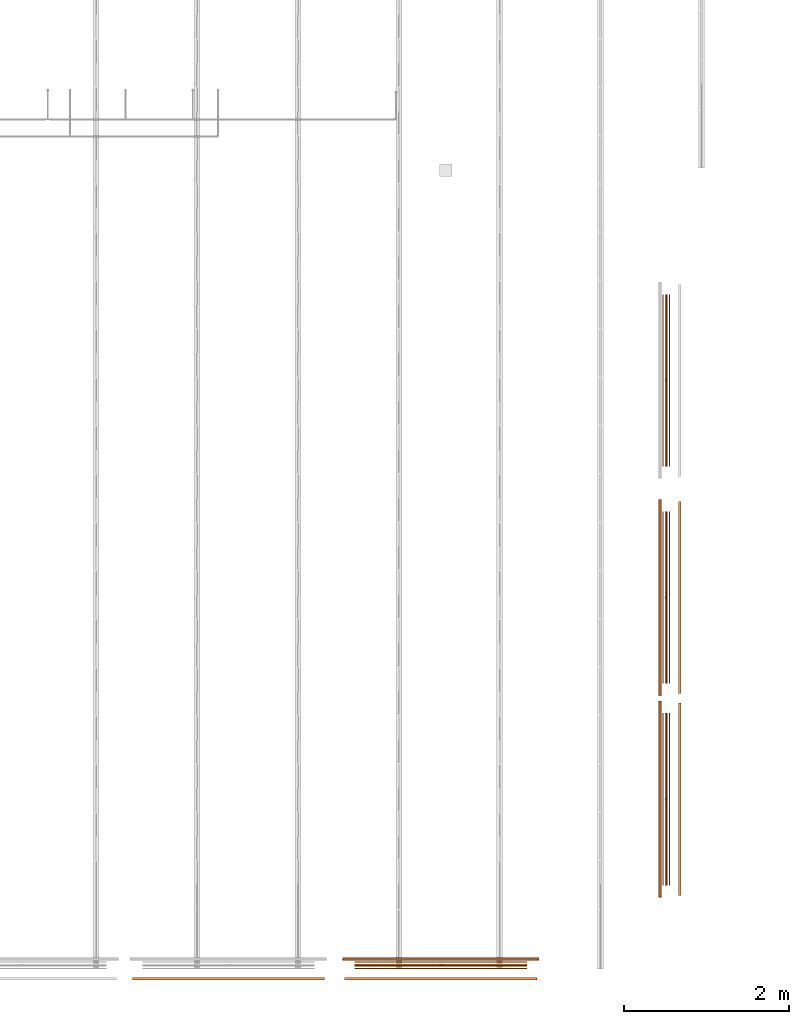
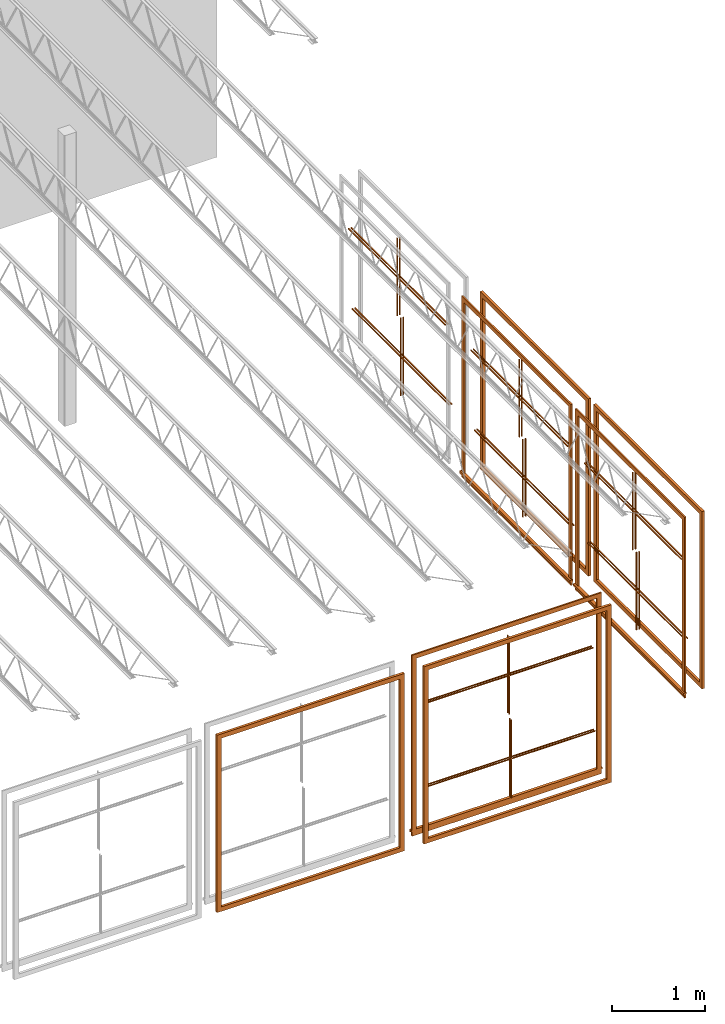
# One storey, part 28 of 31: 15 proxies.
"""IFC2X3 building model written with IfcOpenShell, lengths in feet."""

from ifc_helpers import new_model, entity, si_unit, converted_unit, derived_unit, direction, frame, frame_2d, origin, origin_2d_with_axis, place, context, subcontext, project, spatial, polyline, rectangle, outline, extrude, source, transform, mapped, material, material_list, type_object, type_shapes, element, save


model = new_model("IFC2X3")

# Units and contexts
model_context = context("Model", 3, precision=0.0001, world=origin(), true_north=direction((6.12303176911189e-17, 1.0)))
body_context = subcontext(model_context, "Body", "Model", "MODEL_VIEW")
ifc_project = project(units=[converted_unit("LENGTHUNIT", "FOOT", entity("IfcRatioMeasure", 0.3048), si_unit("LENGTHUNIT", "METRE"), dimensions=[1, 0, 0, 0, 0, 0, 0]), converted_unit("AREAUNIT", "SQUARE FOOT", entity("IfcRatioMeasure", 0.09290304), si_unit("AREAUNIT", "SQUARE_METRE"), dimensions=[2, 0, 0, 0, 0, 0, 0]), converted_unit("VOLUMEUNIT", "CUBIC FOOT", entity("IfcRatioMeasure", 0.028316846592), si_unit("VOLUMEUNIT", "CUBIC_METRE"), dimensions=[3, 0, 0, 0, 0, 0, 0]), converted_unit("PLANEANGLEUNIT", "DEGREE", entity("IfcRatioMeasure", 0.0174532925199433), si_unit("PLANEANGLEUNIT", "RADIAN"), dimensions=[0, 0, 0, 0, 0, 0, 0]), si_unit("MASSUNIT", "GRAM", prefix="KILO"), derived_unit("MASSDENSITYUNIT", [(si_unit("MASSUNIT", "GRAM", prefix="KILO"), 1), (si_unit("LENGTHUNIT", "METRE"), -3)]), si_unit("TIMEUNIT", "SECOND"), si_unit("FREQUENCYUNIT", "HERTZ"), si_unit("THERMODYNAMICTEMPERATUREUNIT", "DEGREE_CELSIUS"), derived_unit("THERMALTRANSMITTANCEUNIT", [(si_unit("MASSUNIT", "GRAM", prefix="KILO"), 1), (si_unit("THERMODYNAMICTEMPERATUREUNIT", "KELVIN"), -1), (si_unit("TIMEUNIT", "SECOND"), -3)]), derived_unit("VOLUMETRICFLOWRATEUNIT", [(si_unit("LENGTHUNIT", "METRE"), 3), (si_unit("TIMEUNIT", "SECOND"), -1)]), si_unit("ELECTRICCURRENTUNIT", "AMPERE"), si_unit("ELECTRICVOLTAGEUNIT", "VOLT"), si_unit("POWERUNIT", "WATT"), si_unit("FORCEUNIT", "NEWTON"), si_unit("ILLUMINANCEUNIT", "LUX"), si_unit("LUMINOUSFLUXUNIT", "LUMEN"), si_unit("LUMINOUSINTENSITYUNIT", "CANDELA"), derived_unit("USERDEFINED", [(si_unit("MASSUNIT", "GRAM", prefix="KILO"), -1), (si_unit("LENGTHUNIT", "METRE"), -2), (si_unit("TIMEUNIT", "SECOND"), 3), (si_unit("LUMINOUSFLUXUNIT", "LUMEN"), 1)]), derived_unit("LINEARVELOCITYUNIT", [(si_unit("LENGTHUNIT", "METRE"), 1), (si_unit("TIMEUNIT", "SECOND"), -1)]), si_unit("PRESSUREUNIT", "PASCAL"), derived_unit("USERDEFINED", [(si_unit("LENGTHUNIT", "METRE"), -2), (si_unit("MASSUNIT", "GRAM", prefix="KILO"), 1), (si_unit("TIMEUNIT", "SECOND"), -2)])], contexts=[model_context])

# Site, building, storey
site_placement = place(None, origin())
site = spatial("IfcSite", under=ifc_project, at=site_placement, CompositionType="ELEMENT")
building_placement = place(site_placement, origin())
building = spatial("IfcBuilding", under=site, at=building_placement, CompositionType="ELEMENT")
storey_placement = place(building_placement, frame((0.0, 0.0, 13.3333333333323)))
storey = spatial("IfcBuildingStorey", under=building, at=storey_placement, Name="Level 2", CompositionType="ELEMENT", Elevation=13.3333333333323)

# Proxies
ifc_material_1 = material(Name="Wood - Stained")
building_element_proxy_type_1 = type_object("IfcBuildingElementProxyType", Name="Trim-Window-Interior-Flat:Picture Frame", PredefinedType="NOTDEFINED", material=ifc_material_1)
shared_shape_1 = source(origin(), body_context, "Body", "SweptSolid", [
    extrude(outline(polyline([(-3.81249999999999, -3.81249999999998), (3.81249999999999, -3.81249999999998), (3.81249999999999, 3.81249999999998), (-3.81249999999999, 3.81249999999998), (-3.81249999999999, -3.81249999999998)]), holes=[polyline([(3.625, 3.62499999999997), (3.625, -3.62499999999998), (-3.62499999999999, -3.62499999999998), (-3.62499999999999, 3.62499999999997), (3.625, 3.62499999999997)])]), frame((32.9591979395684, -37.4400600419649, 20.0), z_axis=(0.0, 1.0, 0.0), x_axis=(1.0, 0.0, 0.0)), (0.0, 0.0, 1.0), 0.104166666666664),
])
type_shapes(building_element_proxy_type_1, [shared_shape_1])
proxy_1_placement = place(building_placement, origin())
element("IfcBuildingElementProxy", 1, at=proxy_1_placement, inside=storey, type_object=building_element_proxy_type_1, material=ifc_material_1, ObjectType="Picture Frame : Trim-Window-Interior-Flat:Picture Frame", context=body_context, shape_type="MappedRepresentation", body=[
    mapped(shared_shape_1, transform((0.0, 0.0, 0.0), scale=1.0)),
])
ifc_material_2 = material(Name="Clad - White 61141")
ifc_material_list_1 = material_list([ifc_material_1, ifc_material_2])
ifc_material_list_2 = material_list([ifc_material_1, ifc_material_2])
building_element_proxy_type_2 = type_object("IfcBuildingElementProxyType", Name="Muntin Pattern_2x2:Muntin Pattern_2x2", PredefinedType="NOTDEFINED", material=ifc_material_list_2)
shared_shape_2 = source(origin(), body_context, "Body", "SweptSolid", [
    extrude(outline(polyline([(-0.0208333333334068, -1.67187499999988), (0.0208333333332575, -1.67187499999988), (0.0208333333332575, -0.0208333333333712), (3.41666666666681, -0.0208333333333712), (3.41666666666681, 0.0208333333332931), (0.020833333333286, 0.0208333333332931), (0.020833333333286, 1.67187500000004), (-0.0208333333333854, 1.67187500000004), (-0.0208333333333854, 0.0208333333333037), (-3.41666666666651, 0.0208333333333037), (-3.41666666666651, -0.0208333333333641), (-0.0208333333334068, -0.0208333333333641), (-0.0208333333334068, -1.67187499999988)])), frame((41.3758646062349, -36.8567267086316, 21.7447916666666), z_axis=(0.0, 1.0, 0.0), x_axis=(1.0, 0.0, 0.0)), (0.0, 0.0, 1.0), 0.0416666666666572),
    extrude(outline(polyline([(-0.0208333333334139, -1.6718749999996), (0.0208333333332433, -1.6718749999996), (0.0208333333332433, -0.0208333333334636), (3.41666666666681, -0.0208333333334636), (3.41666666666681, 0.0208333333331936), (0.0208333333332718, 0.0208333333331936), (0.0208333333332718, 1.67187500000009), (-0.0208333333333783, 1.67187500000009), (-0.0208333333333783, 0.0208333333332149), (-3.4166666666665, 0.0208333333332149), (-3.4166666666665, -0.0208333333334494), (-0.0208333333334139, -0.0208333333334494), (-0.0208333333334139, -1.6718749999996)])), frame((41.3758646062349, -36.7525600419649, 21.7447916666663), z_axis=(0.0, 1.0, 0.0), x_axis=(1.0, 0.0, 0.0)), (0.0, 0.0, 1.0), 0.0416666666666501),
])
type_shapes(building_element_proxy_type_2, [shared_shape_2])
proxy_2_placement = place(building_placement, origin())
element("IfcBuildingElementProxy", 2, at=proxy_2_placement, inside=storey, type_object=building_element_proxy_type_2, material=ifc_material_list_1, ObjectType="Muntin Pattern_2x2 : Muntin Pattern_2x2:Muntin Pattern_2x2", context=body_context, shape_type="MappedRepresentation", body=[
    mapped(shared_shape_2, transform((0.0, 0.0, 0.0), scale=1.0)),
])
ifc_material_list_3 = material_list([ifc_material_1, ifc_material_2])
ifc_material_list_4 = material_list([ifc_material_1, ifc_material_2])
building_element_proxy_type_3 = type_object("IfcBuildingElementProxyType", Name="Muntin Pattern_2x2:Muntin Pattern_2x2", PredefinedType="NOTDEFINED", material=ifc_material_list_4)
shared_shape_3 = source(origin(), body_context, "Body", "SweptSolid", [
    extrude(outline(polyline([(-0.0208333333334068, -1.67187499999989), (0.0208333333332575, -1.67187499999989), (0.0208333333332575, -0.0208333333333748), (3.41666666666681, -0.0208333333333748), (3.41666666666681, 0.0208333333332895), (0.020833333333286, 0.0208333333332895), (0.020833333333286, 1.67187500000003), (-0.0208333333333854, 1.67187500000003), (-0.0208333333333854, 0.0208333333333002), (-3.41666666666651, 0.0208333333333002), (-3.41666666666651, -0.0208333333333677), (-0.0208333333334068, -0.0208333333333677), (-0.0208333333334068, -1.67187499999989)])), frame((41.3758646062349, -37.0025600419649, 18.2552083333333), z_axis=(0.0, 1.0, 0.0), x_axis=(1.0, 0.0, 0.0)), (0.0, 0.0, 1.0), 0.0416666666666572),
    extrude(outline(polyline([(-0.0208333333334139, -1.6718749999996), (0.0208333333332433, -1.6718749999996), (0.0208333333332433, -0.0208333333334672), (3.41666666666681, -0.0208333333334672), (3.41666666666681, 0.02083333333319), (0.0208333333332718, 0.02083333333319), (0.0208333333332718, 1.67187500000009), (-0.0208333333333783, 1.67187500000009), (-0.0208333333333783, 0.0208333333332149), (-3.4166666666665, 0.0208333333332149), (-3.4166666666665, -0.0208333333334458), (-0.0208333333334139, -0.0208333333334458), (-0.0208333333334139, -1.6718749999996)])), frame((41.3758646062349, -36.8983933752982, 18.2552083333331), z_axis=(0.0, 1.0, 0.0), x_axis=(1.0, 0.0, 0.0)), (0.0, 0.0, 1.0), 0.0416666666666501),
])
type_shapes(building_element_proxy_type_3, [shared_shape_3])
proxy_3_placement = place(building_placement, origin())
element("IfcBuildingElementProxy", 3, at=proxy_3_placement, inside=storey, type_object=building_element_proxy_type_3, material=ifc_material_list_3, ObjectType="Muntin Pattern_2x2 : Muntin Pattern_2x2:Muntin Pattern_2x2", context=body_context, shape_type="MappedRepresentation", body=[
    mapped(shared_shape_3, transform((0.0, 0.0, 0.0), scale=1.0)),
])
building_element_proxy_type_4 = type_object("IfcBuildingElementProxyType", Name="Trim-Window-Exterior-Flat:with Sill", PredefinedType="NOTDEFINED", material=ifc_material_2)
shared_shape_4 = source(origin(), body_context, "Body", "SweptSolid", [
    extrude(outline(polyline([(-3.85416666666666, -3.71354166666667), (-3.66666666666666, -3.71354166666667), (-3.66666666666666, 3.61979166666666), (3.66666666666666, 3.61979166666666), (3.66666666666666, -3.71354166666667), (3.85416666666666, -3.71354166666667), (3.85416666666666, 3.80729166666666), (-3.85416666666666, 3.80729166666666), (-3.85416666666666, -3.71354166666667)])), frame((41.3758646062351, -36.6692267086316, 20.046875), z_axis=(0.0, 1.0, 0.0), x_axis=(-1.0, 0.0, 0.0)), (0.0, 0.0, 1.0), 0.0625),
    extrude(outline(polyline([(0.0, -0.0524593146393144), (0.0624999999999574, -0.0524593146393144), (0.0624999999999574, 0.0436428358983321), (0.0, 0.0517073520273605), (-0.0624999999999218, 0.0517073520273605), (-0.0624999999999218, -0.0210694553372015), (0.0, -0.0210694553372015), (0.0, -0.0524593146393144)])), frame((37.4800312729017, -36.6067267086316, 16.2816259813059), z_axis=(1.0, 0.0, 0.0), x_axis=(0.0, 1.0, 0.0)), (0.0, 0.0, 1.0), 7.79166666666668),
    extrude(rectangle(XDim=0.0625, YDim=7.70833333333333, at=origin_2d_with_axis()), frame((41.3758646062351, -36.6379767086316, 16.0730565259687), z_axis=(0.0, 0.0, 1.0), x_axis=(0.0, -1.0, 0.0)), (0.0, 0.0, 1.0), 0.187500000000004),
])
type_shapes(building_element_proxy_type_4, [shared_shape_4])
proxy_4_placement = place(building_placement, origin())
element("IfcBuildingElementProxy", 4, at=proxy_4_placement, inside=storey, type_object=building_element_proxy_type_4, material=ifc_material_2, ObjectType="with Sill : Trim-Window-Exterior-Flat:with Sill", context=body_context, shape_type="MappedRepresentation", body=[
    mapped(shared_shape_4, transform((0.0, 0.0, 0.0), scale=1.0)),
])
building_element_proxy_type_5 = type_object("IfcBuildingElementProxyType", Name="Trim-Window-Interior-Flat:Picture Frame", PredefinedType="NOTDEFINED", material=ifc_material_1)
shared_shape_5 = source(origin(), body_context, "Body", "SweptSolid", [
    extrude(outline(polyline([(-3.81249999999999, -3.81249999999998), (3.81249999999999, -3.81249999999998), (3.81249999999999, 3.81249999999998), (-3.81249999999999, 3.81249999999998), (-3.81249999999999, -3.81249999999998)]), holes=[polyline([(3.625, 3.62499999999997), (3.625, -3.62499999999998), (-3.62499999999999, -3.62499999999998), (-3.62499999999999, 3.62499999999997), (3.625, 3.62499999999997)])]), frame((41.3758646062351, -37.4400600419649, 20.0), z_axis=(0.0, 1.0, 0.0), x_axis=(1.0, 0.0, 0.0)), (0.0, 0.0, 1.0), 0.104166666666664),
])
type_shapes(building_element_proxy_type_5, [shared_shape_5])
proxy_5_placement = place(building_placement, origin())
element("IfcBuildingElementProxy", 5, at=proxy_5_placement, inside=storey, type_object=building_element_proxy_type_5, material=ifc_material_1, ObjectType="Picture Frame : Trim-Window-Interior-Flat:Picture Frame", context=body_context, shape_type="MappedRepresentation", body=[
    mapped(shared_shape_5, transform((0.0, 0.0, 0.0), scale=1.0)),
])
ifc_material_list_5 = material_list([ifc_material_1, ifc_material_2])
ifc_material_list_6 = material_list([ifc_material_1, ifc_material_2])
building_element_proxy_type_6 = type_object("IfcBuildingElementProxyType", Name="Muntin Pattern_2x2:Muntin Pattern_2x2", PredefinedType="NOTDEFINED", material=ifc_material_list_6)
shared_shape_6 = source(origin(), body_context, "Body", "SweptSolid", [
    extrude(outline(polyline([(-1.67187499999989, 0.0208333333334103), (-1.67187499999989, -0.0208333333332504), (-0.0208333333333748, -0.0208333333332504), (-0.0208333333333748, -3.4166666666668), (0.0208333333332895, -3.4166666666668), (0.0208333333332895, -0.0208333333332753), (1.67187500000003, -0.0208333333332753), (1.67187500000003, 0.0208333333333961), (0.0208333333333002, 0.0208333333333961), (0.0208333333333002, 3.41666666666652), (-0.0208333333333677, 3.41666666666652), (-0.0208333333333677, 0.0208333333334103), (-1.67187499999989, 0.0208333333334103)])), frame((50.2764992691725, -30.2753340999124, 21.7447916666666), z_axis=(-1.0, 0.0, 0.0), x_axis=(0.0, 0.0, -1.0)), (0.0, 0.0, -1.0), 0.0416666666666572),
    extrude(outline(polyline([(-1.6718749999996, 0.0208333333334245), (-1.6718749999996, -0.0208333333332362), (-0.0208333333334672, -0.0208333333332362), (-0.0208333333334672, -3.4166666666668), (0.02083333333319, -3.4166666666668), (0.02083333333319, -0.0208333333332646), (1.67187500000009, -0.0208333333332646), (1.67187500000009, 0.020833333333389), (0.0208333333332114, 0.020833333333389), (0.0208333333332114, 3.41666666666651), (-0.0208333333334529, 3.41666666666651), (-0.0208333333334529, 0.0208333333334245), (-1.6718749999996, 0.0208333333334245)])), frame((50.1723326025058, -30.2753340999124, 21.7447916666663), z_axis=(-1.0, 0.0, 0.0), x_axis=(0.0, 0.0, -1.0)), (0.0, 0.0, -1.0), 0.0416666666666501),
])
type_shapes(building_element_proxy_type_6, [shared_shape_6])
proxy_6_placement = place(building_placement, origin())
element("IfcBuildingElementProxy", 6, at=proxy_6_placement, inside=storey, type_object=building_element_proxy_type_6, material=ifc_material_list_5, ObjectType="Muntin Pattern_2x2 : Muntin Pattern_2x2:Muntin Pattern_2x2", context=body_context, shape_type="MappedRepresentation", body=[
    mapped(shared_shape_6, transform((0.0, 0.0, 0.0), scale=1.0)),
])
ifc_material_list_7 = material_list([ifc_material_1, ifc_material_2])
ifc_material_list_8 = material_list([ifc_material_1, ifc_material_2])
building_element_proxy_type_7 = type_object("IfcBuildingElementProxyType", Name="Muntin Pattern_2x2:Muntin Pattern_2x2", PredefinedType="NOTDEFINED", material=ifc_material_list_8)
shared_shape_7 = source(origin(), body_context, "Body", "SweptSolid", [
    extrude(outline(polyline([(-1.67187499999989, 0.0208333333334103), (-1.67187499999989, -0.0208333333332504), (-0.0208333333333748, -0.0208333333332504), (-0.0208333333333748, -3.4166666666668), (0.0208333333332895, -3.4166666666668), (0.0208333333332895, -0.0208333333332753), (1.67187500000003, -0.0208333333332753), (1.67187500000003, 0.0208333333333961), (0.0208333333333002, 0.0208333333333961), (0.0208333333333002, 3.41666666666651), (-0.0208333333333677, 3.41666666666651), (-0.0208333333333677, 0.0208333333334103), (-1.67187499999989, 0.0208333333334103)])), frame((50.4223326025059, -30.2753340999124, 18.2552083333333), z_axis=(-1.0, 0.0, 0.0), x_axis=(0.0, 0.0, -1.0)), (0.0, 0.0, -1.0), 0.0416666666666572),
    extrude(outline(polyline([(-1.6718749999996, 0.0208333333334245), (-1.6718749999996, -0.0208333333332362), (-0.0208333333334672, -0.0208333333332362), (-0.0208333333334672, -3.4166666666668), (0.02083333333319, -3.4166666666668), (0.02083333333319, -0.0208333333332646), (1.67187500000009, -0.0208333333332646), (1.67187500000009, 0.020833333333389), (0.0208333333332149, 0.020833333333389), (0.0208333333332149, 3.41666666666651), (-0.0208333333334458, 3.41666666666651), (-0.0208333333334458, 0.0208333333334245), (-1.6718749999996, 0.0208333333334245)])), frame((50.3181659358392, -30.2753340999124, 18.2552083333331), z_axis=(-1.0, 0.0, 0.0), x_axis=(0.0, 0.0, -1.0)), (0.0, 0.0, -1.0), 0.0416666666666501),
])
type_shapes(building_element_proxy_type_7, [shared_shape_7])
proxy_7_placement = place(building_placement, origin())
element("IfcBuildingElementProxy", 7, at=proxy_7_placement, inside=storey, type_object=building_element_proxy_type_7, material=ifc_material_list_7, ObjectType="Muntin Pattern_2x2 : Muntin Pattern_2x2:Muntin Pattern_2x2", context=body_context, shape_type="MappedRepresentation", body=[
    mapped(shared_shape_7, transform((0.0, 0.0, 0.0), scale=1.0)),
])
building_element_proxy_type_8 = type_object("IfcBuildingElementProxyType", Name="Trim-Window-Exterior-Flat:with Sill", PredefinedType="NOTDEFINED", material=ifc_material_2)
shared_shape_8 = source(origin(), body_context, "Body", "SweptSolid", [
    extrude(outline(polyline([(-3.71354166666666, -3.85416666666667), (3.80729166666667, -3.85416666666667), (3.80729166666667, 3.85416666666665), (-3.71354166666666, 3.85416666666665), (-3.71354166666666, 3.66666666666666), (3.61979166666666, 3.66666666666666), (3.61979166666666, -3.66666666666666), (-3.71354166666666, -3.66666666666666), (-3.71354166666666, -3.85416666666667)])), frame((50.0681659358392, -30.2753340999122, 20.046875), z_axis=(1.0, 0.0, 0.0), x_axis=(0.0, 0.0, 1.0)), (0.0, 0.0, 1.0), 0.0625),
    extrude(outline(polyline([(0.0, -0.0524593146393144), (0.0624999999999503, -0.0524593146393144), (0.0624999999999503, 0.0436428358983321), (0.0, 0.0517073520273605), (-0.0624999999999289, 0.0517073520273605), (-0.0624999999999289, -0.0210694553372015), (0.0, -0.0210694553372015), (0.0, -0.0524593146393144)])), frame((50.0681659358392, -34.1711674332456, 16.2816259813059), z_axis=(0.0, 1.0, 0.0), x_axis=(-1.0, 0.0, 0.0)), (0.0, 0.0, 1.0), 7.79166666666668),
    extrude(rectangle(XDim=0.0625, YDim=7.70833333333332, at=frame_2d((0.0, -1.77635683940025e-15), x_axis=(1.0, 0.0))), frame((50.0994159358392, -30.2753340999122, 16.0730565259687)), (0.0, 0.0, 1.0), 0.187500000000004),
])
type_shapes(building_element_proxy_type_8, [shared_shape_8])
proxy_8_placement = place(building_placement, origin())
element("IfcBuildingElementProxy", 8, at=proxy_8_placement, inside=storey, type_object=building_element_proxy_type_8, material=ifc_material_2, ObjectType="with Sill : Trim-Window-Exterior-Flat:with Sill", context=body_context, shape_type="MappedRepresentation", body=[
    mapped(shared_shape_8, transform((0.0, 0.0, 0.0), scale=1.0)),
])
building_element_proxy_type_9 = type_object("IfcBuildingElementProxyType", Name="Trim-Window-Interior-Flat:Picture Frame", PredefinedType="NOTDEFINED", material=ifc_material_1)
shared_shape_9 = source(origin(), body_context, "Body", "SweptSolid", [
    extrude(outline(polyline([(-3.81249999999998, -3.81249999999999), (3.81249999999998, -3.81249999999999), (3.81249999999998, 3.81249999999999), (-3.81249999999998, 3.81249999999999), (-3.81249999999998, -3.81249999999999)]), holes=[polyline([(3.62499999999997, 3.625), (3.62499999999997, -3.62499999999999), (-3.62499999999998, -3.62499999999999), (-3.62499999999998, 3.625), (3.62499999999997, 3.625)])]), frame((50.7973326025058, -30.2753340999123, 20.0), z_axis=(1.0, 0.0, 0.0), x_axis=(0.0, 0.0, -1.0)), (0.0, 0.0, 1.0), 0.104166666666664),
])
type_shapes(building_element_proxy_type_9, [shared_shape_9])
proxy_9_placement = place(building_placement, origin())
element("IfcBuildingElementProxy", 9, at=proxy_9_placement, inside=storey, type_object=building_element_proxy_type_9, material=ifc_material_1, ObjectType="Picture Frame : Trim-Window-Interior-Flat:Picture Frame", context=body_context, shape_type="MappedRepresentation", body=[
    mapped(shared_shape_9, transform((0.0, 0.0, 0.0), scale=1.0)),
])
ifc_material_list_9 = material_list([ifc_material_1, ifc_material_2])
ifc_material_list_10 = material_list([ifc_material_1, ifc_material_2])
building_element_proxy_type_10 = type_object("IfcBuildingElementProxyType", Name="Muntin Pattern_2x2:Muntin Pattern_2x2", PredefinedType="NOTDEFINED", material=ifc_material_list_10)
shared_shape_10 = source(origin(), body_context, "Body", "SweptSolid", [
    extrude(outline(polyline([(-1.67187499999989, 0.0208333333334139), (-1.67187499999989, -0.0208333333332469), (-0.0208333333333748, -0.0208333333332469), (-0.0208333333333748, -3.4166666666668), (0.0208333333332895, -3.4166666666668), (0.0208333333332895, -0.0208333333332718), (1.67187500000003, -0.0208333333332718), (1.67187500000003, 0.0208333333333997), (0.0208333333333002, 0.0208333333333997), (0.0208333333333002, 3.41666666666652), (-0.0208333333333677, 3.41666666666652), (-0.0208333333333677, 0.0208333333334139), (-1.67187499999989, 0.0208333333334139)])), frame((50.2764992691726, -22.2753340999124, 21.7447916666666), z_axis=(-1.0, 0.0, 0.0), x_axis=(0.0, 0.0, -1.0)), (0.0, 0.0, -1.0), 0.0416666666666572),
    extrude(outline(polyline([(-1.6718749999996, 0.0208333333334245), (-1.6718749999996, -0.0208333333332362), (-0.0208333333334672, -0.0208333333332362), (-0.0208333333334672, -3.4166666666668), (0.02083333333319, -3.4166666666668), (0.02083333333319, -0.0208333333332646), (1.67187500000009, -0.0208333333332646), (1.67187500000009, 0.020833333333389), (0.0208333333332114, 0.020833333333389), (0.0208333333332114, 3.41666666666652), (-0.0208333333334529, 3.41666666666652), (-0.0208333333334529, 0.0208333333334245), (-1.6718749999996, 0.0208333333334245)])), frame((50.1723326025058, -22.2753340999124, 21.7447916666663), z_axis=(-1.0, 0.0, 0.0), x_axis=(0.0, 0.0, -1.0)), (0.0, 0.0, -1.0), 0.0416666666666501),
])
type_shapes(building_element_proxy_type_10, [shared_shape_10])
proxy_10_placement = place(building_placement, origin())
element("IfcBuildingElementProxy", 10, at=proxy_10_placement, inside=storey, type_object=building_element_proxy_type_10, material=ifc_material_list_9, ObjectType="Muntin Pattern_2x2 : Muntin Pattern_2x2:Muntin Pattern_2x2", context=body_context, shape_type="MappedRepresentation", body=[
    mapped(shared_shape_10, transform((0.0, 0.0, 0.0), scale=1.0)),
])
ifc_material_list_11 = material_list([ifc_material_1, ifc_material_2])
ifc_material_list_12 = material_list([ifc_material_1, ifc_material_2])
building_element_proxy_type_11 = type_object("IfcBuildingElementProxyType", Name="Muntin Pattern_2x2:Muntin Pattern_2x2", PredefinedType="NOTDEFINED", material=ifc_material_list_12)
shared_shape_11 = source(origin(), body_context, "Body", "SweptSolid", [
    extrude(outline(polyline([(-1.67187499999989, 0.0208333333334103), (-1.67187499999989, -0.0208333333332504), (-0.0208333333333748, -0.0208333333332504), (-0.0208333333333748, -3.4166666666668), (0.0208333333332895, -3.4166666666668), (0.0208333333332895, -0.0208333333332753), (1.67187500000003, -0.0208333333332753), (1.67187500000003, 0.0208333333333961), (0.0208333333333002, 0.0208333333333961), (0.0208333333333002, 3.41666666666652), (-0.0208333333333677, 3.41666666666652), (-0.0208333333333677, 0.0208333333334103), (-1.67187499999989, 0.0208333333334103)])), frame((50.4223326025059, -22.2753340999124, 18.2552083333333), z_axis=(-1.0, 0.0, 0.0), x_axis=(0.0, 0.0, -1.0)), (0.0, 0.0, -1.0), 0.0416666666666572),
    extrude(outline(polyline([(-1.6718749999996, 0.0208333333334245), (-1.6718749999996, -0.0208333333332362), (-0.0208333333334672, -0.0208333333332362), (-0.0208333333334672, -3.4166666666668), (0.02083333333319, -3.4166666666668), (0.02083333333319, -0.0208333333332646), (1.67187500000009, -0.0208333333332646), (1.67187500000009, 0.020833333333389), (0.0208333333332149, 0.020833333333389), (0.0208333333332149, 3.41666666666651), (-0.0208333333334458, 3.41666666666651), (-0.0208333333334458, 0.0208333333334245), (-1.6718749999996, 0.0208333333334245)])), frame((50.3181659358392, -22.2753340999124, 18.2552083333331), z_axis=(-1.0, 0.0, 0.0), x_axis=(0.0, 0.0, -1.0)), (0.0, 0.0, -1.0), 0.0416666666666501),
])
type_shapes(building_element_proxy_type_11, [shared_shape_11])
proxy_11_placement = place(building_placement, origin())
element("IfcBuildingElementProxy", 11, at=proxy_11_placement, inside=storey, type_object=building_element_proxy_type_11, material=ifc_material_list_11, ObjectType="Muntin Pattern_2x2 : Muntin Pattern_2x2:Muntin Pattern_2x2", context=body_context, shape_type="MappedRepresentation", body=[
    mapped(shared_shape_11, transform((0.0, 0.0, 0.0), scale=1.0)),
])
building_element_proxy_type_12 = type_object("IfcBuildingElementProxyType", Name="Trim-Window-Exterior-Flat:with Sill", PredefinedType="NOTDEFINED", material=ifc_material_2)
shared_shape_12 = source(origin(), body_context, "Body", "SweptSolid", [
    extrude(outline(polyline([(-3.71354166666666, -3.85416666666667), (3.80729166666667, -3.85416666666667), (3.80729166666667, 3.85416666666665), (-3.71354166666666, 3.85416666666665), (-3.71354166666666, 3.66666666666666), (3.61979166666666, 3.66666666666666), (3.61979166666666, -3.66666666666666), (-3.71354166666666, -3.66666666666666), (-3.71354166666666, -3.85416666666667)])), frame((50.0681659358392, -22.2753340999122, 20.046875), z_axis=(1.0, 0.0, 0.0), x_axis=(0.0, 0.0, 1.0)), (0.0, 0.0, 1.0), 0.0625),
    extrude(outline(polyline([(0.0, -0.0524593146393144), (0.0624999999999503, -0.0524593146393144), (0.0624999999999503, 0.0436428358983321), (0.0, 0.0517073520273605), (-0.0624999999999289, 0.0517073520273605), (-0.0624999999999289, -0.0210694553372015), (0.0, -0.0210694553372015), (0.0, -0.0524593146393144)])), frame((50.0681659358392, -26.1711674332456, 16.2816259813059), z_axis=(0.0, 1.0, 0.0), x_axis=(-1.0, 0.0, 0.0)), (0.0, 0.0, 1.0), 7.79166666666668),
    extrude(rectangle(XDim=0.0625, YDim=7.70833333333332, at=origin_2d_with_axis()), frame((50.0994159358392, -22.2753340999122, 16.0730565259687)), (0.0, 0.0, 1.0), 0.187500000000004),
])
type_shapes(building_element_proxy_type_12, [shared_shape_12])
proxy_12_placement = place(building_placement, origin())
element("IfcBuildingElementProxy", 12, at=proxy_12_placement, inside=storey, type_object=building_element_proxy_type_12, material=ifc_material_2, ObjectType="with Sill : Trim-Window-Exterior-Flat:with Sill", context=body_context, shape_type="MappedRepresentation", body=[
    mapped(shared_shape_12, transform((0.0, 0.0, 0.0), scale=1.0)),
])
building_element_proxy_type_13 = type_object("IfcBuildingElementProxyType", Name="Trim-Window-Interior-Flat:Picture Frame", PredefinedType="NOTDEFINED", material=ifc_material_1)
shared_shape_13 = source(origin(), body_context, "Body", "SweptSolid", [
    extrude(outline(polyline([(-3.81249999999998, -3.81249999999999), (3.81249999999998, -3.81249999999999), (3.81249999999998, 3.81249999999999), (-3.81249999999998, 3.81249999999999), (-3.81249999999998, -3.81249999999999)]), holes=[polyline([(3.62499999999997, 3.625), (3.62499999999997, -3.62499999999999), (-3.62499999999998, -3.62499999999999), (-3.62499999999998, 3.625), (3.62499999999997, 3.625)])]), frame((50.7973326025059, -22.2753340999123, 20.0), z_axis=(1.0, 0.0, 0.0), x_axis=(0.0, 0.0, -1.0)), (0.0, 0.0, 1.0), 0.104166666666664),
])
type_shapes(building_element_proxy_type_13, [shared_shape_13])
proxy_13_placement = place(building_placement, origin())
element("IfcBuildingElementProxy", 13, at=proxy_13_placement, inside=storey, type_object=building_element_proxy_type_13, material=ifc_material_1, ObjectType="Picture Frame : Trim-Window-Interior-Flat:Picture Frame", context=body_context, shape_type="MappedRepresentation", body=[
    mapped(shared_shape_13, transform((0.0, 0.0, 0.0), scale=1.0)),
])
ifc_material_list_13 = material_list([ifc_material_1, ifc_material_2])
ifc_material_list_14 = material_list([ifc_material_1, ifc_material_2])
building_element_proxy_type_14 = type_object("IfcBuildingElementProxyType", Name="Muntin Pattern_2x2:Muntin Pattern_2x2", PredefinedType="NOTDEFINED", material=ifc_material_list_14)
shared_shape_14 = source(origin(), body_context, "Body", "SweptSolid", [
    extrude(outline(polyline([(-1.67187499999989, 0.0208333333334121), (-1.67187499999989, -0.0208333333332487), (-0.0208333333333748, -0.0208333333332487), (-0.0208333333333748, -3.4166666666668), (0.0208333333332895, -3.4166666666668), (0.0208333333332895, -0.0208333333332771), (1.67187500000003, -0.0208333333332771), (1.67187500000003, 0.0208333333333961), (0.0208333333333002, 0.0208333333333961), (0.0208333333333002, 3.41666666666652), (-0.0208333333333677, 3.41666666666652), (-0.0208333333333677, 0.0208333333334121), (-1.67187499999989, 0.0208333333334121)])), frame((50.2764992691726, -13.6692267086318, 21.7447916666666), z_axis=(-1.0, 0.0, 0.0), x_axis=(0.0, 0.0, -1.0)), (0.0, 0.0, -1.0), 0.0416666666666572),
    extrude(outline(polyline([(-1.6718749999996, 0.020833333333421), (-1.6718749999996, -0.0208333333332398), (-0.0208333333334672, -0.0208333333332398), (-0.0208333333334672, -3.41666666666681), (0.02083333333319, -3.41666666666681), (0.02083333333319, -0.0208333333332682), (1.67187500000009, -0.0208333333332682), (1.67187500000009, 0.0208333333333837), (0.0208333333332114, 0.0208333333333837), (0.0208333333332114, 3.41666666666651), (-0.0208333333334529, 3.41666666666651), (-0.0208333333334529, 0.020833333333421), (-1.6718749999996, 0.020833333333421)])), frame((50.1723326025059, -13.6692267086318, 21.7447916666663), z_axis=(-1.0, 0.0, 0.0), x_axis=(0.0, 0.0, -1.0)), (0.0, 0.0, -1.0), 0.0416666666666501),
])
type_shapes(building_element_proxy_type_14, [shared_shape_14])
proxy_14_placement = place(building_placement, origin())
element("IfcBuildingElementProxy", 14, at=proxy_14_placement, inside=storey, type_object=building_element_proxy_type_14, material=ifc_material_list_13, ObjectType="Muntin Pattern_2x2 : Muntin Pattern_2x2:Muntin Pattern_2x2", context=body_context, shape_type="MappedRepresentation", body=[
    mapped(shared_shape_14, transform((0.0, 0.0, 0.0), scale=1.0)),
])
ifc_material_list_15 = material_list([ifc_material_1, ifc_material_2])
ifc_material_list_16 = material_list([ifc_material_1, ifc_material_2])
building_element_proxy_type_15 = type_object("IfcBuildingElementProxyType", Name="Muntin Pattern_2x2:Muntin Pattern_2x2", PredefinedType="NOTDEFINED", material=ifc_material_list_16)
shared_shape_15 = source(origin(), body_context, "Body", "SweptSolid", [
    extrude(outline(polyline([(-1.67187499999989, 0.0208333333334139), (-1.67187499999989, -0.0208333333332469), (-0.0208333333333748, -0.0208333333332469), (-0.0208333333333748, -3.4166666666668), (0.0208333333332895, -3.4166666666668), (0.0208333333332895, -0.0208333333332753), (1.67187500000003, -0.0208333333332753), (1.67187500000003, 0.0208333333333979), (0.0208333333333002, 0.0208333333333979), (0.0208333333333002, 3.41666666666652), (-0.0208333333333677, 3.41666666666652), (-0.0208333333333677, 0.0208333333334139), (-1.67187499999989, 0.0208333333334139)])), frame((50.4223326025059, -13.6692267086318, 18.2552083333333), z_axis=(-1.0, 0.0, 0.0), x_axis=(0.0, 0.0, -1.0)), (0.0, 0.0, -1.0), 0.0416666666666572),
    extrude(outline(polyline([(-1.6718749999996, 0.0208333333334192), (-1.6718749999996, -0.0208333333332416), (-0.0208333333334672, -0.0208333333332416), (-0.0208333333334672, -3.41666666666681), (0.02083333333319, -3.41666666666681), (0.02083333333319, -0.02083333333327), (1.67187500000009, -0.02083333333327), (1.67187500000009, 0.0208333333333819), (0.0208333333332149, 0.0208333333333819), (0.0208333333332149, 3.4166666666665), (-0.0208333333334458, 3.4166666666665), (-0.0208333333334458, 0.0208333333334192), (-1.6718749999996, 0.0208333333334192)])), frame((50.3181659358392, -13.6692267086318, 18.2552083333331), z_axis=(-1.0, 0.0, 0.0), x_axis=(0.0, 0.0, -1.0)), (0.0, 0.0, -1.0), 0.0416666666666501),
])
type_shapes(building_element_proxy_type_15, [shared_shape_15])
proxy_15_placement = place(building_placement, origin())
element("IfcBuildingElementProxy", 15, at=proxy_15_placement, inside=storey, type_object=building_element_proxy_type_15, material=ifc_material_list_15, ObjectType="Muntin Pattern_2x2 : Muntin Pattern_2x2:Muntin Pattern_2x2", context=body_context, shape_type="MappedRepresentation", body=[
    mapped(shared_shape_15, transform((0.0, 0.0, 0.0), scale=1.0)),
])

save(model, "model.ifc")
